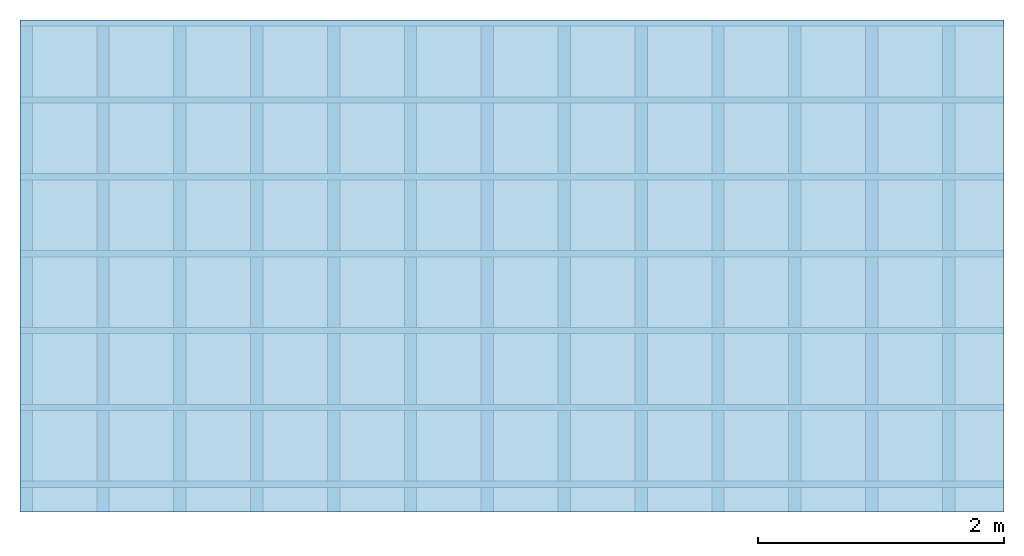
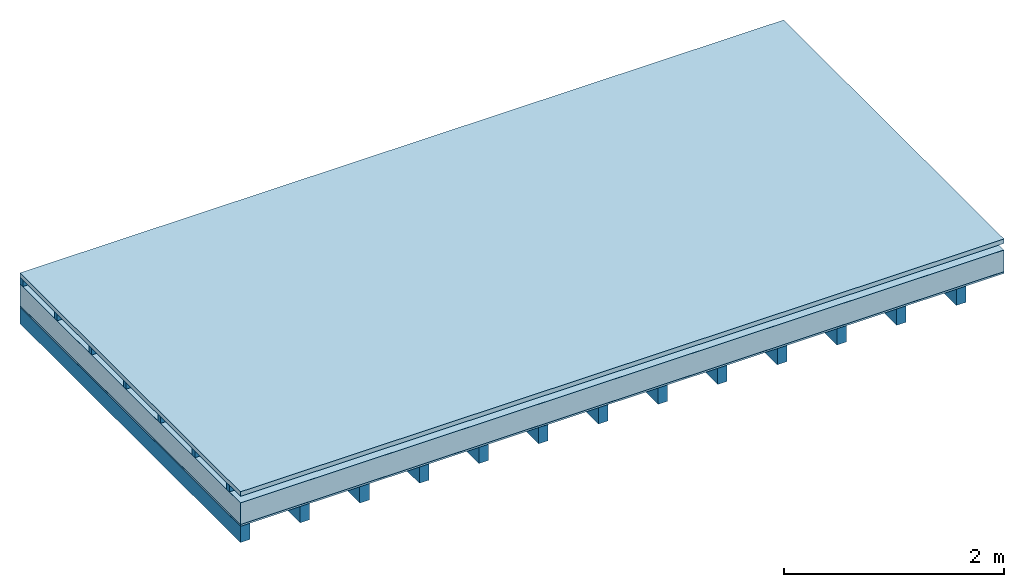
# One storey: 5 plates, 2 members, 1 element without a shape of its own.
"""IFC4 building model written with IfcOpenShell, lengths in metres."""

from ifc_helpers import new_model, si_unit, derived_unit, direction, frame, frame_2d, origin, origin_with_axes, place, context, project, spatial, rectangle, extrude, material, layer, layer_set, type_object, element, aggregate, save


model = new_model("IFC4")

# Units and contexts
plan_context = context("Plan", 3, precision=1e-05, world=origin(), true_north=direction((0.0, 1.0)))
model_context = context("Model", 3, precision=1e-05, world=origin(), true_north=direction((0.0, 1.0)))
ifc_project = project(units=[si_unit("LENGTHUNIT", "METRE"), derived_unit("SOUNDPRESSUREUNIT", [(si_unit("PRESSUREUNIT", "PASCAL", prefix="MICRO"), 0)]), si_unit("ENERGYUNIT", "JOULE", prefix="MEGA"), si_unit("MASSUNIT", "GRAM", prefix="KILO"), derived_unit("THERMALTRANSMITTANCEUNIT", [(si_unit("POWERUNIT", "WATT"), 1), (si_unit("AREAUNIT", "SQUARE_METRE"), -1), (si_unit("THERMODYNAMICTEMPERATUREUNIT", "KELVIN"), -1)]), derived_unit("AREADENSITYUNIT", [(si_unit("MASSUNIT", "GRAM", prefix="KILO"), 1), (si_unit("AREAUNIT", "SQUARE_METRE"), -1)]), derived_unit("USERDEFINED", [(si_unit("ENERGYUNIT", "JOULE", prefix="MEGA"), 1), (si_unit("AREAUNIT", "SQUARE_METRE"), -1)])], contexts=[plan_context, model_context])

# Site, building, storey
site = spatial("IfcSite", under=ifc_project)
building_placement = place(None, origin())
building = spatial("IfcBuilding", under=site, at=building_placement)
storey_placement = place(building_placement, origin())
storey = spatial("IfcBuildingStorey", under=building, at=storey_placement)

# Slab, members, plates
ifc_material_1 = material(Name="Roof tiles", Category="03.015")
ifc_layer_1 = layer(ifc_material_1, 0.05, Name="Roofing")
ifc_layer_2 = layer(None, 0.072, Name="Battens / profiles")
ifc_material_2 = material(Name="Roofing underlay", Category="09.008")
ifc_layer_3 = layer(ifc_material_2, 0.00018, Name="Under the roof")
ifc_material_3 = material(Category="10.009")
ifc_layer_4 = layer(ifc_material_3, 0.24, Name="Exterior insulation layer 1")
ifc_material_4 = material(Name="Vapor barrier polyethylene (PE)", Category="09.002")
ifc_layer_5 = layer(ifc_material_4, 0.00018, Name="above 1st layer")
ifc_material_5 = material(Name="Boards with edges", Category="07.009")
ifc_layer_6 = layer(ifc_material_5, 0.02, Name="Sub-floor")
ifc_material_6 = material(Name="of the art")
ifc_layer_7 = layer(ifc_material_6, 0.0, Name="Bond")
ifc_layer_8 = layer(None, 0.18, Name="Supporting structure")
ifc_layer_set = layer_set([ifc_layer_1, ifc_layer_2, ifc_layer_3, ifc_layer_4, ifc_layer_5, ifc_layer_6, ifc_layer_7, ifc_layer_8])
slab_type = type_object("IfcSlabType", Name="E0174", PredefinedType="NOTDEFINED", material=ifc_layer_set)
slab_placement = place(None, frame((0.0, 0.0, 0.0), z_axis=(0.0, 0.0, -1.0), x_axis=(1.0, 0.0, 0.0)))
slab = element("IfcSlab", 1, at=slab_placement, inside=storey, type_object=slab_type, material=ifc_layer_set, Name="Slab #1")
ifc_material_7 = material()
member_1_placement = place(slab_placement, origin())
member_1 = element("IfcMember", 2, at=member_1_placement, material=ifc_material_7, Name="Battens / profiles", context=plan_context, shape_type="SweptSolid", body=[
    extrude(rectangle(XDim=0.05, YDim=0.072, at=frame_2d((0.025, 0.036), x_axis=(1.0, 0.0))), frame((0.0, 0.0, 0.05), z_axis=(1.0, 0.0, 0.0), x_axis=(0.0, 1.0, 0.0)), (0.0, 0.0, 1.0), 8.0),
    extrude(rectangle(XDim=0.05, YDim=0.072, at=frame_2d((0.025, 0.036), x_axis=(1.0, 0.0))), frame((0.0, 0.625, 0.05), z_axis=(1.0, 0.0, 0.0), x_axis=(0.0, 1.0, 0.0)), (0.0, 0.0, 1.0), 8.0),
    extrude(rectangle(XDim=0.05, YDim=0.072, at=frame_2d((0.025, 0.036), x_axis=(1.0, 0.0))), frame((0.0, 1.25, 0.05), z_axis=(1.0, 0.0, 0.0), x_axis=(0.0, 1.0, 0.0)), (0.0, 0.0, 1.0), 8.0),
    extrude(rectangle(XDim=0.05, YDim=0.072, at=frame_2d((0.025, 0.036), x_axis=(1.0, 0.0))), frame((0.0, 1.875, 0.05), z_axis=(1.0, 0.0, 0.0), x_axis=(0.0, 1.0, 0.0)), (0.0, 0.0, 1.0), 8.0),
    extrude(rectangle(XDim=0.05, YDim=0.072, at=frame_2d((0.025, 0.036), x_axis=(1.0, 0.0))), frame((0.0, 2.5, 0.05), z_axis=(1.0, 0.0, 0.0), x_axis=(0.0, 1.0, 0.0)), (0.0, 0.0, 1.0), 8.0),
    extrude(rectangle(XDim=0.05, YDim=0.072, at=frame_2d((0.025, 0.036), x_axis=(1.0, 0.0))), frame((0.0, 3.125, 0.05), z_axis=(1.0, 0.0, 0.0), x_axis=(0.0, 1.0, 0.0)), (0.0, 0.0, 1.0), 8.0),
    extrude(rectangle(XDim=0.05, YDim=0.072, at=frame_2d((0.025, 0.036), x_axis=(1.0, 0.0))), frame((0.0, 3.75, 0.05), z_axis=(1.0, 0.0, 0.0), x_axis=(0.0, 1.0, 0.0)), (0.0, 0.0, 1.0), 8.0),
])
ifc_material_8 = material()
member_2_placement = place(slab_placement, origin())
member_2 = element("IfcMember", 3, at=member_2_placement, material=ifc_material_8, Name="Supporting structure", context=plan_context, shape_type="SweptSolid", body=[
    extrude(rectangle(XDim=0.1, YDim=0.18, at=frame_2d((0.05, 0.09), x_axis=(1.0, 0.0))), frame((0.0, 4.0, 0.38236), z_axis=(0.0, -1.0, 0.0), x_axis=(1.0, 0.0, 0.0)), (0.0, 0.0, 1.0), 4.0),
    extrude(rectangle(XDim=0.1, YDim=0.18, at=frame_2d((0.05, 0.09), x_axis=(1.0, 0.0))), frame((0.625, 4.0, 0.38236), z_axis=(0.0, -1.0, 0.0), x_axis=(1.0, 0.0, 0.0)), (0.0, 0.0, 1.0), 4.0),
    extrude(rectangle(XDim=0.1, YDim=0.18, at=frame_2d((0.05, 0.09), x_axis=(1.0, 0.0))), frame((1.25, 4.0, 0.38236), z_axis=(0.0, -1.0, 0.0), x_axis=(1.0, 0.0, 0.0)), (0.0, 0.0, 1.0), 4.0),
    extrude(rectangle(XDim=0.1, YDim=0.18, at=frame_2d((0.05, 0.09), x_axis=(1.0, 0.0))), frame((1.875, 4.0, 0.38236), z_axis=(0.0, -1.0, 0.0), x_axis=(1.0, 0.0, 0.0)), (0.0, 0.0, 1.0), 4.0),
    extrude(rectangle(XDim=0.1, YDim=0.18, at=frame_2d((0.05, 0.09), x_axis=(1.0, 0.0))), frame((2.5, 4.0, 0.38236), z_axis=(0.0, -1.0, 0.0), x_axis=(1.0, 0.0, 0.0)), (0.0, 0.0, 1.0), 4.0),
    extrude(rectangle(XDim=0.1, YDim=0.18, at=frame_2d((0.05, 0.09), x_axis=(1.0, 0.0))), frame((3.125, 4.0, 0.38236), z_axis=(0.0, -1.0, 0.0), x_axis=(1.0, 0.0, 0.0)), (0.0, 0.0, 1.0), 4.0),
    extrude(rectangle(XDim=0.1, YDim=0.18, at=frame_2d((0.05, 0.09), x_axis=(1.0, 0.0))), frame((3.75, 4.0, 0.38236), z_axis=(0.0, -1.0, 0.0), x_axis=(1.0, 0.0, 0.0)), (0.0, 0.0, 1.0), 4.0),
    extrude(rectangle(XDim=0.1, YDim=0.18, at=frame_2d((0.05, 0.09), x_axis=(1.0, 0.0))), frame((4.375, 4.0, 0.38236), z_axis=(0.0, -1.0, 0.0), x_axis=(1.0, 0.0, 0.0)), (0.0, 0.0, 1.0), 4.0),
    extrude(rectangle(XDim=0.1, YDim=0.18, at=frame_2d((0.05, 0.09), x_axis=(1.0, 0.0))), frame((5.0, 4.0, 0.38236), z_axis=(0.0, -1.0, 0.0), x_axis=(1.0, 0.0, 0.0)), (0.0, 0.0, 1.0), 4.0),
    extrude(rectangle(XDim=0.1, YDim=0.18, at=frame_2d((0.05, 0.09), x_axis=(1.0, 0.0))), frame((5.625, 4.0, 0.38236), z_axis=(0.0, -1.0, 0.0), x_axis=(1.0, 0.0, 0.0)), (0.0, 0.0, 1.0), 4.0),
    extrude(rectangle(XDim=0.1, YDim=0.18, at=frame_2d((0.05, 0.09), x_axis=(1.0, 0.0))), frame((6.25, 4.0, 0.38236), z_axis=(0.0, -1.0, 0.0), x_axis=(1.0, 0.0, 0.0)), (0.0, 0.0, 1.0), 4.0),
    extrude(rectangle(XDim=0.1, YDim=0.18, at=frame_2d((0.05, 0.09), x_axis=(1.0, 0.0))), frame((6.875, 4.0, 0.38236), z_axis=(0.0, -1.0, 0.0), x_axis=(1.0, 0.0, 0.0)), (0.0, 0.0, 1.0), 4.0),
    extrude(rectangle(XDim=0.1, YDim=0.18, at=frame_2d((0.05, 0.09), x_axis=(1.0, 0.0))), frame((7.5, 4.0, 0.38236), z_axis=(0.0, -1.0, 0.0), x_axis=(1.0, 0.0, 0.0)), (0.0, 0.0, 1.0), 4.0),
])
plate_1_placement = place(slab_placement, origin())
plate_1 = element("IfcPlate", 4, at=plate_1_placement, material=ifc_material_1, Name="Roofing", context=plan_context, shape_type="SweptSolid", body=[
    extrude(rectangle(XDim=8.0, YDim=4.0, at=frame_2d((4.0, 2.0), x_axis=(1.0, 0.0))), origin_with_axes(), (0.0, 0.0, 1.0), 0.05),
])
plate_2_placement = place(slab_placement, origin())
plate_2 = element("IfcPlate", 5, at=plate_2_placement, material=ifc_material_2, Name="Under the roof", context=plan_context, shape_type="SweptSolid", body=[
    extrude(rectangle(XDim=8.0, YDim=4.0, at=frame_2d((4.0, 2.0), x_axis=(1.0, 0.0))), frame((0.0, 0.0, 0.122), z_axis=(0.0, 0.0, 1.0), x_axis=(1.0, 0.0, 0.0)), (0.0, 0.0, 1.0), 0.00018),
])
plate_3_placement = place(slab_placement, origin())
plate_3 = element("IfcPlate", 6, at=plate_3_placement, material=ifc_material_3, Name="Exterior insulation layer 1", context=plan_context, shape_type="SweptSolid", body=[
    extrude(rectangle(XDim=8.0, YDim=4.0, at=frame_2d((4.0, 2.0), x_axis=(1.0, 0.0))), frame((0.0, 0.0, 0.12218), z_axis=(0.0, 0.0, 1.0), x_axis=(1.0, 0.0, 0.0)), (0.0, 0.0, 1.0), 0.24),
])
plate_4_placement = place(slab_placement, origin())
plate_4 = element("IfcPlate", 7, at=plate_4_placement, material=ifc_material_4, Name="above 1st layer", context=plan_context, shape_type="SweptSolid", body=[
    extrude(rectangle(XDim=8.0, YDim=4.0, at=frame_2d((4.0, 2.0), x_axis=(1.0, 0.0))), frame((0.0, 0.0, 0.36218), z_axis=(0.0, 0.0, 1.0), x_axis=(1.0, 0.0, 0.0)), (0.0, 0.0, 1.0), 0.00018),
])
plate_5_placement = place(slab_placement, origin())
plate_5 = element("IfcPlate", 8, at=plate_5_placement, material=ifc_material_5, Name="Sub-floor", context=plan_context, shape_type="SweptSolid", body=[
    extrude(rectangle(XDim=8.0, YDim=4.0, at=frame_2d((4.0, 2.0), x_axis=(1.0, 0.0))), frame((0.0, 0.0, 0.36236), z_axis=(0.0, 0.0, 1.0), x_axis=(1.0, 0.0, 0.0)), (0.0, 0.0, 1.0), 0.02),
])
aggregate(slab, [plate_1, member_1, plate_2, plate_3, plate_4, plate_5, member_2])

save(model, "model.ifc")
